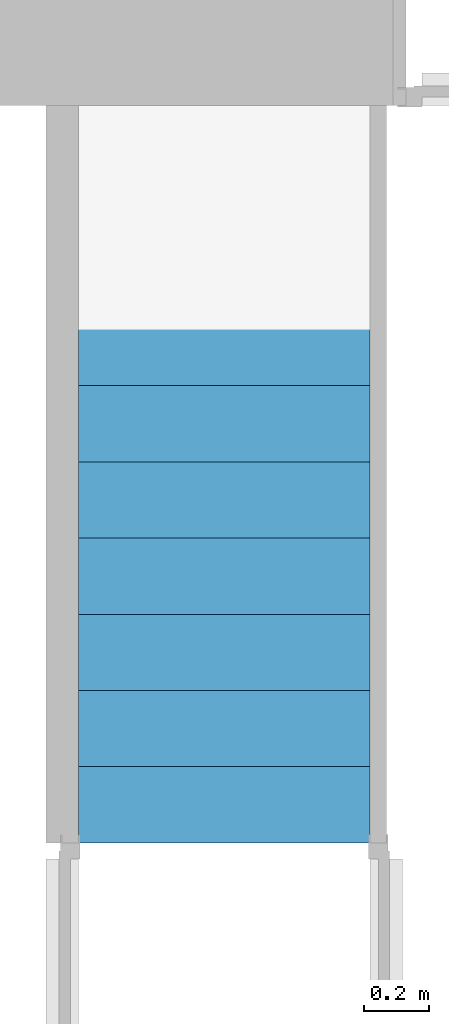
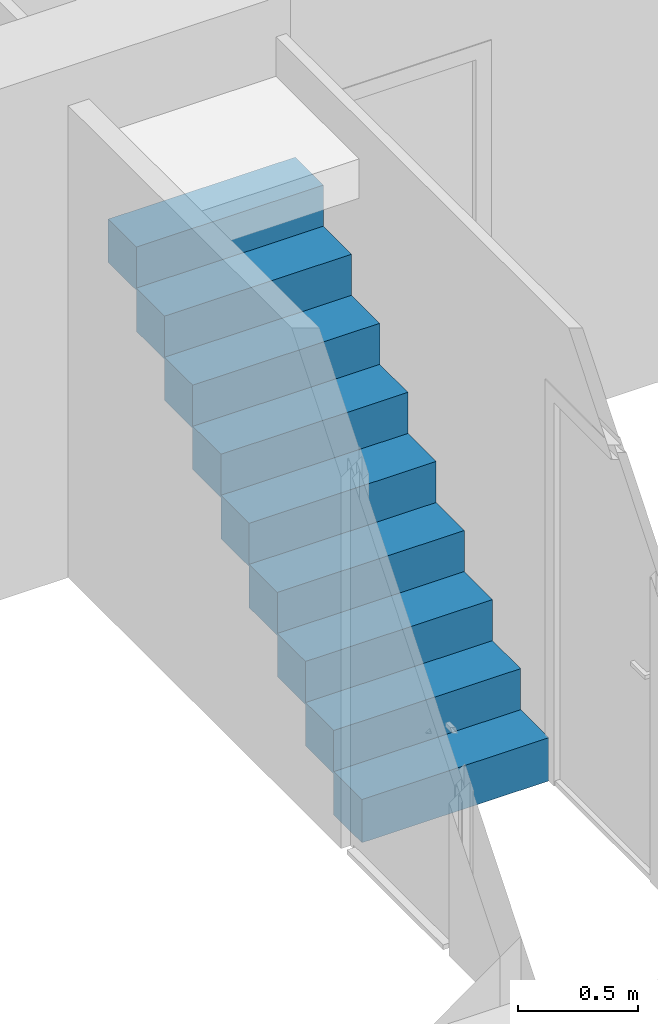
# One storey, part 5 of 6: 1 stair flight.
"""IFC4 building model written with IfcOpenShell, lengths in millimetres."""

from ifc_helpers import new_model, entity, si_unit, converted_unit, frame, origin_with_axes, origin_2d_with_axis, place, context, subcontext, project, spatial, polygons, source, transform, mapped, type_object, type_shapes, element, save


model = new_model("IFC4")

# Units and contexts
model_context = context("Model", 3, precision=1e-05, world=origin_with_axes())
plan_context = context("Plan", 2, precision=1e-05, world=origin_2d_with_axis())
body_context = subcontext(model_context, "Body", "Model", "MODEL_VIEW")
ifc_project = project(units=[si_unit("VOLUMEUNIT", "CUBIC_METRE"), si_unit("LENGTHUNIT", "METRE", prefix="MILLI"), converted_unit("PLANEANGLEUNIT", "degree", entity("IfcReal", 0.0174532925199433), si_unit("PLANEANGLEUNIT", "RADIAN"), dimensions=[0, 0, 0, 0, 0, 0, 0]), si_unit("AREAUNIT", "SQUARE_METRE")], contexts=[model_context, plan_context])

# Site, building, storey
site_placement = place(None, origin_with_axes())
site = spatial("IfcSite", under=ifc_project, at=site_placement)
building_placement = place(site_placement, origin_with_axes())
building = spatial("IfcBuilding", under=site, at=building_placement, Name="Building")
storey_placement = place(building_placement, origin_with_axes())
storey = spatial("IfcBuildingStorey", under=building, at=storey_placement, Name="Ground Floor")

# Stair flight
stair_flight_type = type_object("IfcStairFlightType", Name="STF900", PredefinedType="STRAIGHT")
shared_shape = source(origin_with_axes(), body_context, "Body", "Tessellation", [
    polygons([(0.0, 0.0, -11.1111116409302), (234.999984741211, 0.0, -11.1111116409302), (234.999984741211, 0.0, 208.888900756836), (0.0, 0.0, 208.888900756836), (234.999984741211, 0.0, 197.777786254883), (469.999969482422, 0.0, 197.777786254883), (469.999969482422, 0.0, 417.777801513672), (234.999984741211, 0.0, 417.777801513672), (469.999969482422, 0.0, 406.666687011719), (704.999938964844, 0.0, 406.666687011719), (704.999938964844, 0.0, 626.666687011719), (469.999969482422, 0.0, 626.666687011719), (704.999938964844, 0.0, 615.555541992188), (939.999938964844, 0.0, 615.555541992188), (939.999938964844, 0.0, 835.555603027344), (704.999938964844, 0.0, 835.555603027344), (939.999938964844, 0.0, 824.444458007812), (1174.99987792969, 0.0, 824.444458007812), (1174.99987792969, 0.0, 1044.44445800781), (939.999938964844, 0.0, 1044.44445800781), (1174.99987792969, 0.0, 1033.33337402344), (1409.99987792969, 0.0, 1033.33337402344), (1409.99987792969, 0.0, 1253.33337402344), (1174.99987792969, 0.0, 1253.33337402344), (1409.99987792969, 0.0, 1242.22229003906), (1644.99987792969, 0.0, 1242.22229003906), (1644.99987792969, 0.0, 1462.22229003906), (1409.99987792969, 0.0, 1462.22229003906), (1644.99987792969, 0.0, 1451.11108398438), (1879.99987792969, 0.0, 1451.11108398438), (1879.99987792969, 0.0, 1671.11120605469), (1644.99987792969, 0.0, 1671.11120605469), (1879.99987792969, 0.0, 1660.0), (2115.0, 0.0, 1660.0), (2115.0, 0.0, 1880.0), (1879.99987792969, 0.0, 1880.0), (0.0, 900.0, -11.1111116409302), (0.0, 900.0, 208.888900756836), (234.999984741211, 900.0, 208.888900756836), (234.999984741211, 900.0, -11.1111116409302), (234.999984741211, 900.0, 197.777786254883), (234.999984741211, 900.0, 417.777801513672), (469.999969482422, 900.0, 417.777801513672), (469.999969482422, 900.0, 197.777786254883), (469.999969482422, 900.0, 406.666687011719), (469.999969482422, 900.0, 626.666687011719), (704.999938964844, 900.0, 626.666687011719), (704.999938964844, 900.0, 406.666687011719), (704.999938964844, 900.0, 615.555541992188), (704.999938964844, 900.0, 835.555603027344), (939.999938964844, 900.0, 835.555603027344), (939.999938964844, 900.0, 615.555541992188), (939.999938964844, 900.0, 824.444458007812), (939.999938964844, 900.0, 1044.44445800781), (1174.99987792969, 900.0, 1044.44445800781), (1174.99987792969, 900.0, 824.444458007812), (1174.99987792969, 900.0, 1033.33337402344), (1174.99987792969, 900.0, 1253.33337402344), (1409.99987792969, 900.0, 1253.33337402344), (1409.99987792969, 900.0, 1033.33337402344), (1409.99987792969, 900.0, 1242.22229003906), (1409.99987792969, 900.0, 1462.22229003906), (1644.99987792969, 900.0, 1462.22229003906), (1644.99987792969, 900.0, 1242.22229003906), (1644.99987792969, 900.0, 1451.11108398438), (1644.99987792969, 900.0, 1671.11120605469), (1879.99987792969, 900.0, 1671.11120605469), (1879.99987792969, 900.0, 1451.11108398438), (1879.99987792969, 900.0, 1660.0), (1879.99987792969, 900.0, 1880.0), (2115.0, 900.0, 1880.0), (2115.0, 900.0, 1660.0)], [[[1, 2, 3, 4]], [[5, 6, 7, 8]], [[9, 10, 11, 12]], [[13, 14, 15, 16]], [[17, 18, 19, 20]], [[21, 22, 23, 24]], [[25, 26, 27, 28]], [[29, 30, 31, 32]], [[33, 34, 35, 36]], [[37, 38, 39, 40]], [[41, 42, 43, 44]], [[45, 46, 47, 48]], [[49, 50, 51, 52]], [[53, 54, 55, 56]], [[57, 58, 59, 60]], [[61, 62, 63, 64]], [[65, 66, 67, 68]], [[69, 70, 71, 72]], [[6, 5, 41, 44]], [[29, 32, 66, 65]], [[20, 19, 55, 54]], [[7, 6, 44, 43]], [[34, 33, 69, 72]], [[17, 20, 54, 53]], [[8, 7, 43, 42]], [[35, 34, 72, 71]], [[22, 21, 57, 60]], [[5, 8, 42, 41]], [[36, 35, 71, 70]], [[23, 22, 60, 59]], [[10, 9, 45, 48]], [[33, 36, 70, 69]], [[24, 23, 59, 58]], [[11, 10, 48, 47]], [[21, 24, 58, 57]], [[12, 11, 47, 46]], [[26, 25, 61, 64]], [[9, 12, 46, 45]], [[27, 26, 64, 63]], [[14, 13, 49, 52]], [[28, 27, 63, 62]], [[15, 14, 52, 51]], [[2, 1, 37, 40]], [[25, 28, 62, 61]], [[16, 15, 51, 50]], [[3, 2, 40, 39]], [[30, 29, 65, 68]], [[13, 16, 50, 49]], [[4, 3, 39, 38]], [[31, 30, 68, 67]], [[18, 17, 53, 56]], [[1, 4, 38, 37]], [[32, 31, 67, 66]], [[19, 18, 56, 55]]], closed=True),
])
type_shapes(stair_flight_type, [shared_shape])
stair_flight_placement = place(storey_placement, frame((4380.00011444092, 1775.00009536743, 5.55554963648319), z_axis=(0.0, 0.0, 1.0), x_axis=(-4.37113882867379e-08, 0.999999999999999, 0.0)))
element("IfcStairFlight", 1, at=stair_flight_placement, inside=storey, type_object=stair_flight_type, Name="StairFlight", context=body_context, shape_type="MappedRepresentation", body=[
    mapped(shared_shape, transform((0.0, 0.0, 0.0), x_axis=(1.0, 0.0, 0.0), y_axis=(0.0, 1.0, 0.0), z_axis=(0.0, 0.0, 1.0), scale=1.0)),
])

save(model, "model.ifc")
